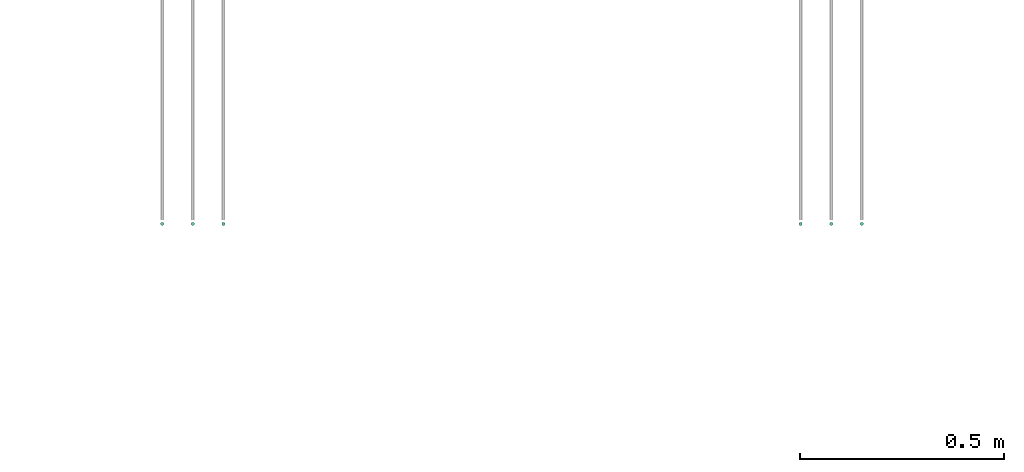
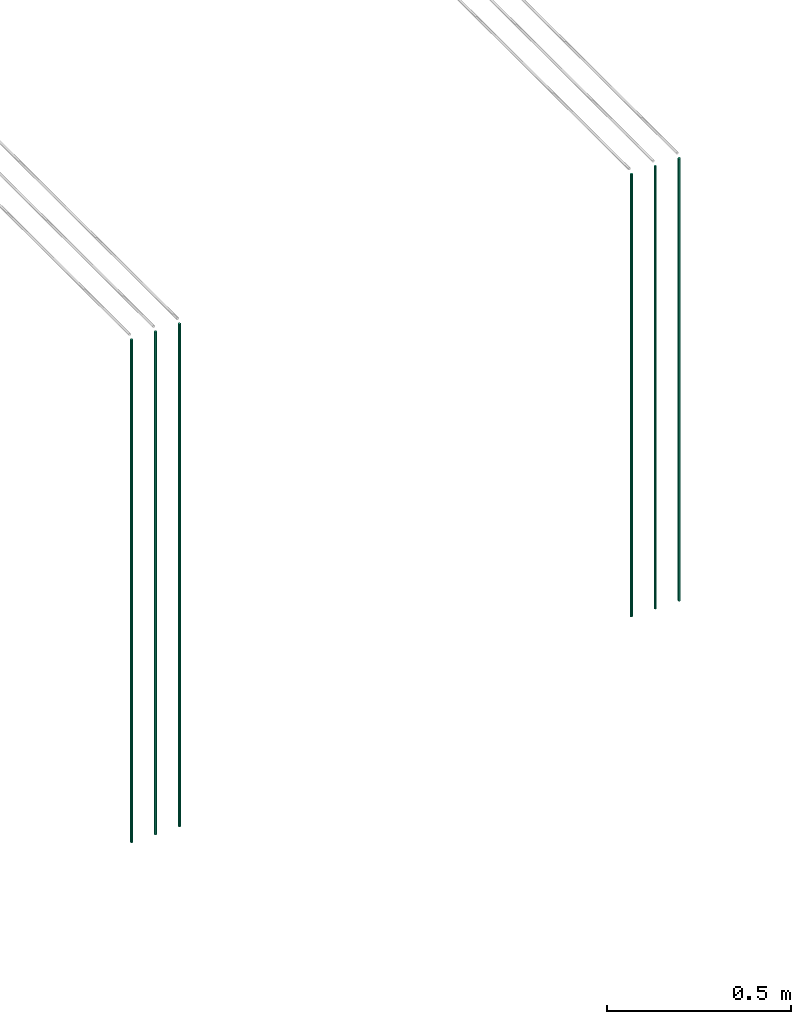
# One storey, part 28 of 89: 9 flow segments.
"""IFC2X3 building model written with IfcOpenShell, lengths in millimetres."""

from ifc_helpers import new_model, entity, si_unit, converted_unit, derived_unit, direction, frame, origin, origin_2d_with_axis, place, context, subcontext, project, spatial, circle, extrude, type_object, element, save


model = new_model("IFC2X3")

# Units and contexts
model_context = context("Model", 3, precision=0.01, world=origin(), true_north=direction((6.12303176911189e-17, 1.0)))
body_context = subcontext(model_context, "Body", "Model", "MODEL_VIEW")
ifc_project = project(units=[si_unit("LENGTHUNIT", "METRE", prefix="MILLI"), si_unit("AREAUNIT", "SQUARE_METRE"), si_unit("VOLUMEUNIT", "CUBIC_METRE"), converted_unit("PLANEANGLEUNIT", "DEGREE", entity("IfcRatioMeasure", 0.0174532925199433), si_unit("PLANEANGLEUNIT", "RADIAN"), dimensions=[0, 0, 0, 0, 0, 0, 0]), si_unit("MASSUNIT", "GRAM", prefix="KILO"), derived_unit("MASSDENSITYUNIT", [(si_unit("MASSUNIT", "GRAM", prefix="KILO"), 1), (si_unit("LENGTHUNIT", "METRE"), -3)]), derived_unit("MOMENTOFINERTIAUNIT", [(si_unit("LENGTHUNIT", "METRE"), 4)]), si_unit("TIMEUNIT", "SECOND"), si_unit("FREQUENCYUNIT", "HERTZ"), si_unit("THERMODYNAMICTEMPERATUREUNIT", "DEGREE_CELSIUS"), derived_unit("THERMALTRANSMITTANCEUNIT", [(si_unit("MASSUNIT", "GRAM", prefix="KILO"), 1), (si_unit("THERMODYNAMICTEMPERATUREUNIT", "KELVIN"), -1), (si_unit("TIMEUNIT", "SECOND"), -3)]), derived_unit("VOLUMETRICFLOWRATEUNIT", [(si_unit("LENGTHUNIT", "METRE"), 3), (si_unit("TIMEUNIT", "SECOND"), -1)]), derived_unit("MASSFLOWRATEUNIT", [(si_unit("MASSUNIT", "GRAM", prefix="KILO"), 1), (si_unit("TIMEUNIT", "SECOND"), -1)]), derived_unit("ROTATIONALFREQUENCYUNIT", [(si_unit("TIMEUNIT", "SECOND"), -1)]), si_unit("ELECTRICCURRENTUNIT", "AMPERE"), si_unit("ELECTRICVOLTAGEUNIT", "VOLT"), si_unit("POWERUNIT", "WATT"), si_unit("FORCEUNIT", "NEWTON", prefix="KILO"), si_unit("ILLUMINANCEUNIT", "LUX"), si_unit("LUMINOUSFLUXUNIT", "LUMEN"), si_unit("LUMINOUSINTENSITYUNIT", "CANDELA"), derived_unit("USERDEFINED", [(si_unit("MASSUNIT", "GRAM", prefix="KILO"), -1), (si_unit("LENGTHUNIT", "METRE"), -2), (si_unit("TIMEUNIT", "SECOND"), 3), (si_unit("LUMINOUSFLUXUNIT", "LUMEN"), 1)]), derived_unit("LINEARVELOCITYUNIT", [(si_unit("LENGTHUNIT", "METRE"), 1), (si_unit("TIMEUNIT", "SECOND"), -1)]), si_unit("PRESSUREUNIT", "PASCAL"), derived_unit("USERDEFINED", [(si_unit("LENGTHUNIT", "METRE"), -2), (si_unit("MASSUNIT", "GRAM", prefix="KILO"), 1), (si_unit("TIMEUNIT", "SECOND"), -2)]), derived_unit("LINEARFORCEUNIT", [(si_unit("MASSUNIT", "GRAM", prefix="KILO"), 1), (si_unit("LENGTHUNIT", "METRE"), 1), (si_unit("TIMEUNIT", "SECOND"), -2), (si_unit("LENGTHUNIT", "METRE"), -1)]), derived_unit("PLANARFORCEUNIT", [(si_unit("MASSUNIT", "GRAM", prefix="KILO"), 1), (si_unit("LENGTHUNIT", "METRE"), 1), (si_unit("TIMEUNIT", "SECOND"), -2), (si_unit("LENGTHUNIT", "METRE"), -2)])], contexts=[model_context])

# Site, building, storey
site_placement = place(None, frame((0.0, -0.00077364408347762, 0.0)))
site = spatial("IfcSite", under=ifc_project, at=site_placement, CompositionType="ELEMENT")
building_placement = place(site_placement, origin())
building = spatial("IfcBuilding", under=site, at=building_placement, CompositionType="ELEMENT")
storey_placement = place(building_placement, frame((0.0, 0.0, 24000.0)))
storey = spatial("IfcBuildingStorey", under=building, at=storey_placement, CompositionType="ELEMENT", Elevation=24000.0)

# Flow segments
pipe_segment_type = type_object("IfcPipeSegmentType", PredefinedType="NOTDEFINED")
for number, where in (
    (1, (61715.5947663164, 14094.4047204552, 1599.29036474498)),
    (2, (61790.6832928663, 14094.4047204552, 1599.29036474498)),
):
    element("IfcFlowSegment", number, at=place(storey_placement, frame(where)), inside=storey, type_object=pipe_segment_type, context=body_context, shape_type="SweptSolid", body=[
        extrude(circle(Radius=4.0, at=origin_2d_with_axis()), frame((5.59527223591499, 5.59527223591499, 0.0)), (0.0, 0.0, 1.0), 1465.70963525503),
    ])
for number, where in (
    (3, (60150.02397103, 14094.4047204552, 1400.0)),
    (4, (60225.0239710301, 14094.4047204552, 1400.0)),
    (5, (60300.0239710301, 14094.4047204552, 1400.0)),
):
    element("IfcFlowSegment", number, at=place(storey_placement, frame(where)), inside=storey, type_object=pipe_segment_type, context=body_context, shape_type="SweptSolid", body=[
        extrude(circle(Radius=4.0, at=origin_2d_with_axis()), frame((5.59527223591499, 5.59527223591499, 0.0)), (0.0, 0.0, 1.0), 1665.00000000002),
    ])
for number, where in (
    (6, (61865.5947663164, 14094.4047204552, 1599.29036474498)),
    (7, (60150.02397103, 14094.4047204552, 1599.29036474498)),
    (8, (60225.1124975799, 14094.4047204552, 1599.29036474498)),
    (9, (60300.02397103, 14094.4047204552, 1599.29036474498)),
):
    element("IfcFlowSegment", number, at=place(storey_placement, frame(where)), inside=storey, type_object=pipe_segment_type, context=body_context, shape_type="SweptSolid", body=[
        extrude(circle(Radius=4.0, at=origin_2d_with_axis()), frame((5.59527223591499, 5.59527223591499, 0.0)), (0.0, 0.0, 1.0), 1465.70963525503),
    ])

save(model, "model.ifc")
